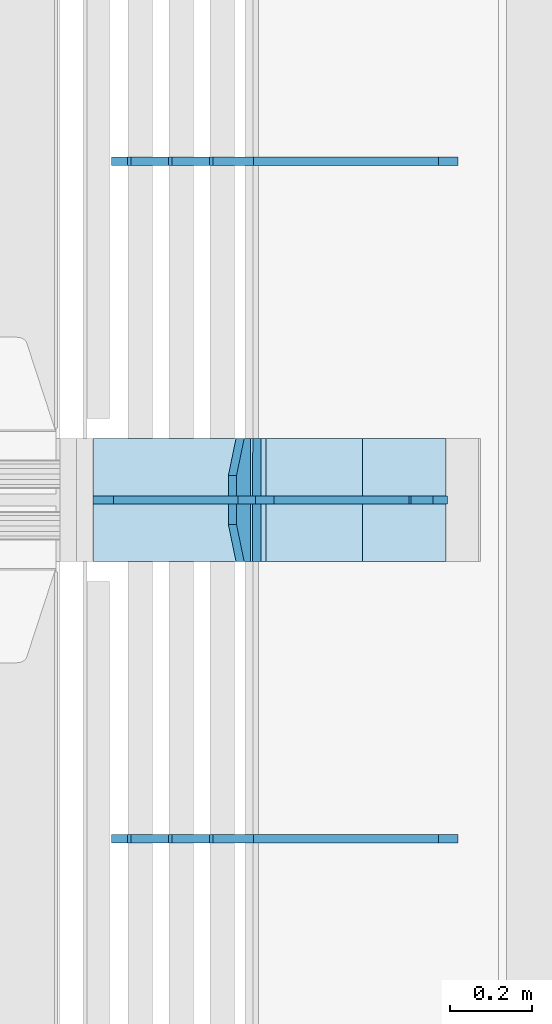
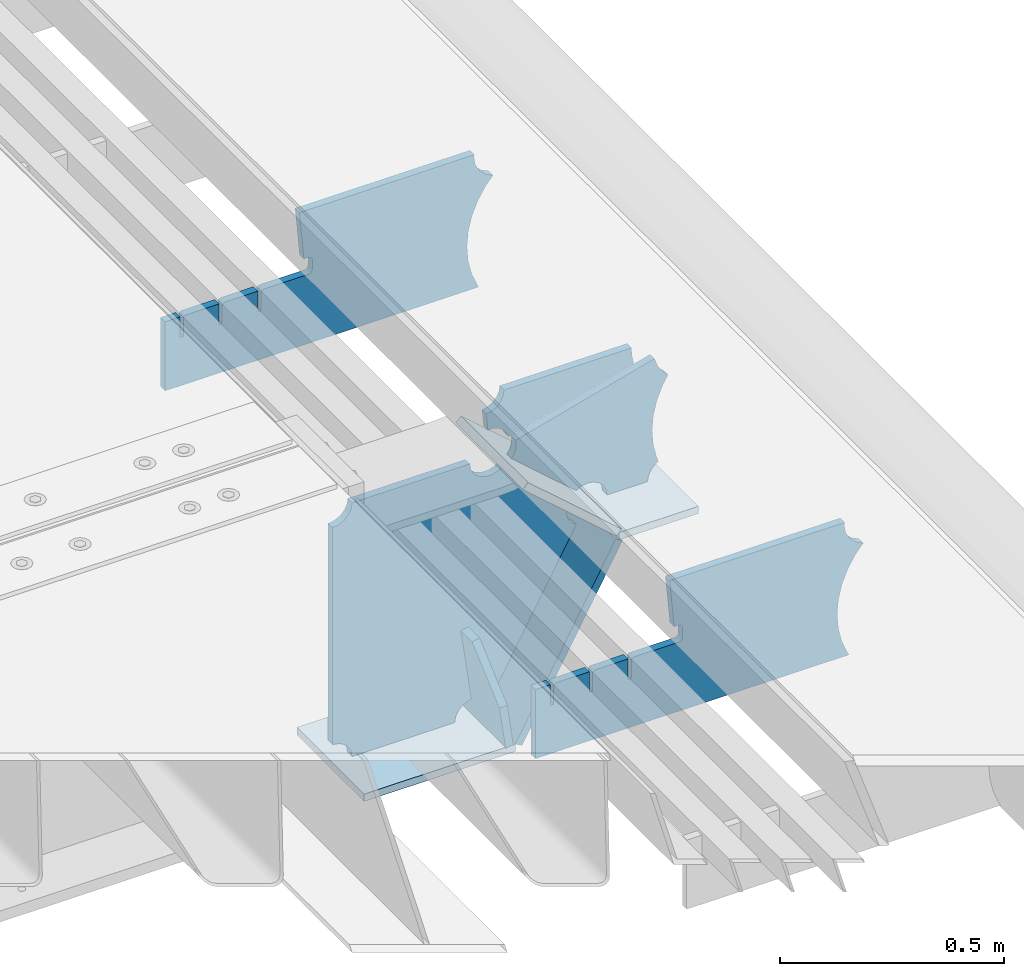
# One storey, part 228 of 247: 10 plates.
"""IFC2X3 building model written with IfcOpenShell, lengths in millimetres."""

from ifc_helpers import new_model, si_unit, frame, origin_with_axes, place, context, subcontext, project, spatial, faceted_brep, material, type_object, element, save


model = new_model("IFC2X3")

# Units and contexts
model_context = context("Model", 3, precision=1e-05, world=origin_with_axes())
body_context = subcontext(model_context, "Body", "Model", "MODEL_VIEW")
ifc_project = project(units=[si_unit("LENGTHUNIT", "METRE", prefix="MILLI"), si_unit("AREAUNIT", "SQUARE_METRE"), si_unit("VOLUMEUNIT", "CUBIC_METRE"), si_unit("MASSUNIT", "GRAM", prefix="KILO"), si_unit("TIMEUNIT", "SECOND"), si_unit("PLANEANGLEUNIT", "RADIAN"), si_unit("SOLIDANGLEUNIT", "STERADIAN"), si_unit("THERMODYNAMICTEMPERATUREUNIT", "DEGREE_CELSIUS"), si_unit("LUMINOUSINTENSITYUNIT", "LUMEN")], contexts=[model_context])

# Site, building, storey
site_placement = place(None, origin_with_axes())
site = spatial("IfcSite", under=ifc_project, at=site_placement, CompositionType="ELEMENT")
building_placement = place(site_placement, origin_with_axes())
building = spatial("IfcBuilding", under=site, at=building_placement, Name="Standard", CompositionType="ELEMENT")
storey_placement = place(building_placement, origin_with_axes())
storey = spatial("IfcBuildingStorey", under=building, at=storey_placement, Name="Undefined", CompositionType="ELEMENT", Elevation=0.0)

# Plates
ifc_material = material(Name="STEEL/S355N")
plate_type_1 = type_object("IfcPlateType", PredefinedType="NOTDEFINED")
plate_1_placement = place(storey_placement, frame((17271.0775331946, 6150.00000000169, -871.412303810021), z_axis=(0.0, -0.999999999999548, -9.5100000000016e-07), x_axis=(-0.137902988002446, 0.0, 0.990445741017648)))
element("IfcPlate", 1, at=plate_1_placement, inside=storey, type_object=plate_type_1, material=ifc_material, context=body_context, shape_type="Brep", body=[
    faceted_brep([(-5.6843418860808e-14, -9.99999999999989, 3.5527136788005e-15), (-1.98724592337385e-10, -10.0000000000036, 300.0), (-1.98724592337385e-10, 10.0, 300.0), (-5.6843418860808e-14, 10.0000000000001, 3.5527136788005e-15), (115.0, -10.0, 300.0), (115.0, 9.99999999999636, 300.0), (250.0, -10.0, 210.0), (250.0, 9.99999999999636, 210.0), (250.0, -10.0, 90.0), (250.0, 9.99999999999636, 90.0), (115.0, -10.0, -1.10503606265411e-10), (115.0, 9.99999999999636, -1.10503606265411e-10)], [[[0, 1, 2, 3]], [[1, 4, 5, 2]], [[4, 6, 7, 5]], [[6, 8, 9, 7]], [[8, 10, 11, 9]], [[10, 0, 3, 11]], [[5, 7, 9, 11, 3, 2]], [[10, 8, 6, 4, 1, 0]]]),
])
plate_type_2 = type_object("IfcPlateType", PredefinedType="NOTDEFINED")
plate_2_placement = place(storey_placement, frame((17299.9988298913, 6000.00000000007, -179.999999999866), z_axis=(0.0, 0.0, -1.0), x_axis=(-1.0, 0.0, 0.0)))
element("IfcPlate", 2, at=plate_2_placement, inside=storey, type_object=plate_type_2, material=ifc_material, context=body_context, shape_type="Brep", body=[
    faceted_brep([(46.0258547361445, 10.0, 641.078828352486), (73.3015011074785, 10.0, 445.179898435767), (73.3015011074785, -10.0, 445.179898435767), (46.0258547361445, -10.0, 641.078828352486), (53.4925862871278, 10.0, 442.421838675718), (53.4925862871278, -10.0, 442.421838675718), (25.7820501123933, 10.0, 641.444230671287), (25.7820501123933, -10.0, 641.444230671287), (54.6652503111618, 10.0, 642.447174185377), (54.6652503111618, -10.0, 642.447174185377), (68.6036632070354, -10.0, 649.549150281387), (68.6036632070354, 10.0, 649.549150281387), (79.6652503111618, -10.0, 660.610737385511), (79.6652503111618, 10.0, 660.610737385511), (86.7672264071698, -10.0, 674.549150281387), (86.7672264071698, 10.0, 674.549150281387), (89.2144005924129, -10.0, 690.0), (89.2144005924129, 10.0, 690.0), (353.0, -10.0, 690.0), (353.0, 10.0, 690.0), (355.447174185243, -10.0, 674.549150281253), (355.447174185243, 10.0, 674.549150281253), (362.549150281251, -10.0, 660.610737385376), (362.549150281251, 10.0, 660.610737385376), (373.610737385377, -10.0, 649.549150281253), (373.610737385377, 10.0, 649.549150281253), (387.549150281251, -10.0, 642.447174185242), (387.549150281251, 10.0, 642.447174185242), (403.0, -10.0, 640.0), (403.0, 10.0, 640.0), (403.0, -10.0, 50.0), (403.0, 10.0, 50.0), (387.549150281251, -10.0, 47.5528258147577), (387.549150281251, 10.0, 47.5528258147577), (373.610737385377, -10.0, 40.4508497187474), (373.610737385377, 10.0, 40.4508497187474), (362.549150281251, -10.0, 29.3892626146236), (362.549150281251, 10.0, 29.3892626146236), (355.447174185243, -10.0, 15.4508497187474), (355.447174185243, 10.0, 15.4508497187474), (353.0, -10.0, 0.0), (353.0, 10.0, 0.0), (50.0, -10.0, 0.0), (50.0, 10.0, 0.0), (47.0349915316328, -10.0, 16.9620037619133), (47.0349915316328, 10.0, 16.9620037619133), (38.4916171352343, -10.0, 31.9123081320451), (38.4916171352343, 10.0, 31.9123081320451), (25.3831239081519, -10.0, 43.0778019479116), (25.3831239081519, 10.0, 43.0778019479116), (9.26418358741648, -10.0, 49.1342538608113), (9.26418358741648, 10.0, 49.1342538608113), (-7.95349204488593, -10.0, 49.363366622344), (-7.95349204488593, 10.0, 49.363366622344), (-24.2278808265401, -10.0, 43.7379673813837), (-24.2278808265401, 10.0, 43.7379673813837), (-37.6288347353438, -10.0, 32.9252303934259), (-37.6288347353438, 10.0, 32.9252303934259), (-210.371165264656, -10.0, 184.074769606574), (-210.371165264656, 10.0, 184.074769606574), (-202.382363280569, -10.0, 196.529747922069), (-202.382363280569, 10.0, 196.529747922069), (-198.388707244045, -10.0, 210.777489969227), (-198.388707244045, 10.0, 210.777489969227), (-198.739957464426, -10.0, 225.570193077959), (-198.739957464426, 10.0, 225.570193077959), (-203.40535180681, -10.0, 239.612327446012), (-203.40535180681, 10.0, 239.612327446012), (-211.976299808361, -10.0, 251.674097313455), (-211.976299808361, 10.0, 251.674097313455), (-223.702166612962, -10.0, 260.699145216992), (-223.702166612962, 10.0, 260.699145216992), (-9.29783338703783, -10.0, 646.300854783008), (-9.29783338703783, 10.0, 646.300854783008), (6.98069453597782, -10.0, 640.647282345602), (6.98069453597782, 10.0, 640.647282345602), (24.2117663163663, -10.0, 640.855891896051), (24.2117663163663, 10.0, 640.855891896051)], [[[0, 1, 2, 3]], [[4, 5, 2, 1]], [[6, 7, 5, 4]], [[8, 9, 10, 11]], [[11, 10, 12, 13]], [[13, 12, 14, 15]], [[15, 14, 16, 17]], [[18, 19, 17, 16]], [[18, 20, 21, 19]], [[20, 22, 23, 21]], [[22, 24, 25, 23]], [[24, 26, 27, 25]], [[26, 28, 29, 27]], [[28, 30, 31, 29]], [[30, 32, 33, 31]], [[32, 34, 35, 33]], [[34, 36, 37, 35]], [[36, 38, 39, 37]], [[38, 40, 41, 39]], [[40, 42, 43, 41]], [[42, 44, 45, 43]], [[44, 46, 47, 45]], [[46, 48, 49, 47]], [[48, 50, 51, 49]], [[50, 52, 53, 51]], [[52, 54, 55, 53]], [[54, 56, 57, 55]], [[56, 58, 59, 57]], [[58, 60, 61, 59]], [[60, 62, 63, 61]], [[62, 64, 65, 63]], [[64, 66, 67, 65]], [[66, 68, 69, 67]], [[68, 70, 71, 69]], [[70, 72, 73, 71]], [[72, 74, 75, 73]], [[74, 76, 77, 75]], [[1, 0, 8, 11, 13, 15, 17, 19, 21, 23, 25, 27, 29, 31, 33, 35, 37, 39, 41, 43, 45, 47, 49, 51, 53, 55, 57, 59, 61, 63, 65, 67, 69, 71, 73, 75, 77, 6, 4]], [[9, 8, 0, 3]], [[76, 74, 72, 70, 68, 66, 64, 62, 60, 58, 56, 54, 52, 50, 48, 46, 44, 42, 40, 38, 36, 34, 32, 30, 28, 26, 24, 22, 20, 18, 16, 14, 12, 10, 9, 3, 2, 5, 7]], [[77, 76, 7, 6]]]),
])
plate_type_3 = type_object("IfcPlateType", PredefinedType="NOTDEFINED")
plate_3_placement = place(storey_placement, frame((17835.9988298906, 6000.0, -9.99999999999716), z_axis=(0.0, 0.0, -1.0), x_axis=(-1.0, 0.0, 0.0)))
element("IfcPlate", 3, at=plate_3_placement, inside=storey, type_object=plate_type_3, material=ifc_material, context=body_context, shape_type="Brep", body=[
    faceted_brep([(164.157641141064, -10.0, 44.1844865875018), (486.718340840864, -10.0, 131.004562768382), (486.718340840864, 10.0, 131.004562768382), (164.157641141064, 10.0, 44.1844865875018), (492.179177700767, -10.0, 118.185717565315), (492.179177700767, 10.0, 118.185717565315), (500.965368826703, -10.0, 107.371542744776), (500.965368826703, 10.0, 107.371542744776), (512.394601349042, -10.0, 99.4018391429503), (512.394601349042, 10.0, 99.4018391429503), (525.579310641864, -10.0, 94.8955133209048), (525.579310641864, 10.0, 94.8955133209048), (539.495606295339, -10.0, 94.2025148824028), (539.495606295339, 10.0, 94.2025148824028), (543.504393704661, -10.0, 49.7974851175972), (543.504393704661, 10.0, 49.7974851175972), (529.167086307516, -10.0, 46.3176139481669), (529.167086307516, 10.0, 46.3176139481669), (516.469507120331, -10.0, 38.8049999196639), (516.469507120331, 10.0, 38.8049999196639), (506.517198234546, -10.0, 27.9137449599276), (506.517198234546, 10.0, 27.9137449599276), (500.17667886756, -10.0, 14.592119649441), (500.17667886756, 10.0, 14.592119649441), (498.0, -10.0, 0.0), (498.0, 10.0, 0.0), (170.0, -10.0, 0.0), (170.0, 10.0, 0.0), (169.632873911985, -10.0, 11.1663820622718), (169.632873911985, 10.0, 11.1663820622718), (168.533081313406, -10.0, 22.2845350637931), (168.533081313406, 10.0, 22.2845350637931), (166.705372351957, -10.0, 33.3064382514178), (166.705372351957, 10.0, 33.3064382514178)], [[[0, 1, 2, 3]], [[1, 4, 5, 2]], [[4, 6, 7, 5]], [[6, 8, 9, 7]], [[8, 10, 11, 9]], [[10, 12, 13, 11]], [[12, 14, 15, 13]], [[14, 16, 17, 15]], [[16, 18, 19, 17]], [[18, 20, 21, 19]], [[20, 22, 23, 21]], [[22, 24, 25, 23]], [[24, 26, 27, 25]], [[26, 28, 29, 27]], [[28, 30, 31, 29]], [[30, 32, 33, 31]], [[32, 0, 3, 33]], [[5, 7, 9, 11, 13, 15, 17, 19, 21, 23, 25, 27, 29, 31, 33, 3, 2]], [[32, 30, 28, 26, 24, 22, 20, 18, 16, 14, 12, 10, 8, 6, 4, 1, 0]]]),
])
plate_type_4 = type_object("IfcPlateType", PredefinedType="NOTDEFINED")
plate_4_placement = place(storey_placement, frame((17840.9988502512, 5999.99999999933, -28.9999913318487), z_axis=(0.260769276985653, 0.0, -0.965401151946889), x_axis=(-0.965401151946889, 0.0, -0.260769276985654)))
element("IfcPlate", 4, at=plate_4_placement, inside=storey, type_object=plate_type_4, material=ifc_material, context=body_context, shape_type="Brep", body=[
    faceted_brep([(183.436474692331, 10.0, 275.852500330424), (184.918388609061, 10.0, 264.417843531322), (184.918388609061, -10.0, 264.417843531322), (183.436474692331, -10.0, 275.852500330424), (183.794583267612, 10.0, 224.576469334607), (183.794583267612, -10.0, 224.576469334607), (176.452049775839, 10.0, 185.401410454621), (176.452049775839, -10.0, 185.401410454621), (163.071585676767, 10.0, 147.857286855558), (163.071585676767, -10.0, 147.857286855558), (143.982662403749, 10.0, 112.868559462227), (143.982662403749, -10.0, 112.868559462227), (119.655312600251, 10.0, 81.2967668639831), (119.655312600251, -10.0, 81.2967668639831), (100.960891712752, 10.0, 63.6280409830933), (100.960891712752, -10.0, 63.6280409830933), (194.486836975902, -10.0, 278.751956446687), (207.178624553377, -10.0, 286.650994937514), (207.178624553377, 10.0, 286.650994937514), (194.486836975902, 10.0, 278.751956446687), (216.968013469446, -10.0, 297.948965801394), (216.968013469446, 10.0, 297.948965801394), (222.979925232863, -10.0, 311.635937633766), (222.979925232863, 10.0, 311.635937633766), (323.381647032762, -10.0, 284.515917834983), (323.381647032762, 10.0, 284.515917834983), (321.720617177336, -10.0, 268.853198956859), (321.720617177336, 10.0, 268.853198956859), (325.01434448114, -10.0, 253.450889283181), (325.01434448114, 10.0, 253.450889283181), (332.935986082481, -10.0, 239.837389469553), (332.935986082481, 10.0, 239.837389469553), (344.699462330093, -10.0, 229.363593146935), (344.699462330093, 10.0, 229.363593146935), (359.137460970807, -10.0, 223.0688351622), (359.137460970807, 10.0, 223.0688351622), (374.817271777687, -10.0, 221.57775639289), (374.817271777687, 10.0, 221.57775639289), (390.182952880859, -10.0, 225.038330078124), (390.182952880859, 10.0, 225.038330078124), (512.90906051303, -10.0, 41.5599003357011), (512.90906051303, 10.0, 41.5599003357011), (503.648024844581, -10.0, 33.5643666747665), (503.648024844581, 10.0, 33.5643666747665), (496.606064569703, -10.0, 23.5590612989981), (496.606064569703, 10.0, 23.5590612989981), (492.204839143935, -10.0, 12.1430832451069), (492.204839143935, 10.0, 12.1430832451069), (490.707885742188, -10.0, 3.79259290639311e-10), (490.707885742188, 10.0, 3.79259290639311e-10), (120.0, -10.0, 9.18589648790658e-11), (120.0, 10.0, 9.18589648790658e-11), (117.226254779114, -10.0, 25.6516118492136), (117.226254779114, 10.0, 25.6516118492136), (109.03324682566, -10.0, 50.1173731020972), (109.03324682566, 10.0, 50.1173731020972)], [[[0, 1, 2, 3]], [[4, 5, 2, 1]], [[6, 7, 5, 4]], [[8, 9, 7, 6]], [[10, 11, 9, 8]], [[12, 13, 11, 10]], [[14, 15, 13, 12]], [[16, 17, 18, 19]], [[17, 20, 21, 18]], [[20, 22, 23, 21]], [[22, 24, 25, 23]], [[24, 26, 27, 25]], [[26, 28, 29, 27]], [[28, 30, 31, 29]], [[30, 32, 33, 31]], [[32, 34, 35, 33]], [[34, 36, 37, 35]], [[36, 38, 39, 37]], [[38, 40, 41, 39]], [[40, 42, 43, 41]], [[42, 44, 45, 43]], [[44, 46, 47, 45]], [[46, 48, 49, 47]], [[48, 50, 51, 49]], [[50, 52, 53, 51]], [[52, 54, 55, 53]], [[10, 8, 6, 4, 1, 0, 19, 18, 21, 23, 25, 27, 29, 31, 33, 35, 37, 39, 41, 43, 45, 47, 49, 51, 53, 55, 14, 12]], [[16, 19, 0, 3]], [[54, 52, 50, 48, 46, 44, 42, 40, 38, 36, 34, 32, 30, 28, 26, 24, 22, 20, 17, 16, 3, 2, 5, 7, 9, 11, 13, 15]], [[55, 54, 15, 14]]]),
])
plate_type_5 = type_object("IfcPlateType", PredefinedType="NOTDEFINED")
plate_5_placement = place(storey_placement, frame((17312.2260590443, 6149.99999999933, -177.219372761326), z_axis=(0.752414935148685, 0.0, -0.658689430130164), x_axis=(0.0, -0.999999999999548, -9.5100000000016e-07)))
element("IfcPlate", 5, at=plate_5_placement, inside=storey, type_object=plate_type_5, material=ifc_material, context=body_context, shape_type="Brep", body=[
    faceted_brep([(-5.6843418860808e-14, -9.99999999999989, 3.5527136788005e-15), (1.09139364212751e-10, -10.0000000000018, 320.0), (1.09139364212751e-10, 9.99999999999818, 319.999999999998), (-5.6843418860808e-14, 10.0000000000001, 3.5527136788005e-15), (300.0, -10.0000000000018, 320.0), (300.0, 9.99999999999818, 319.999999999998), (300.0, -10.0, 6.54836185276508e-11), (300.0, 9.99999999999818, 6.54836185276508e-11)], [[[0, 1, 2, 3]], [[1, 4, 5, 2]], [[4, 6, 7, 5]], [[6, 0, 3, 7]], [[5, 7, 3, 2]], [[6, 4, 1, 0]]]),
])
plate_6_placement = place(storey_placement, frame((17553.0007288108, 6150.00000000007, -408.004820491625), z_axis=(-0.484064236150485, 0.0, -0.875032465272031), x_axis=(0.0, -0.999999999999548, -9.5100000000016e-07)))
element("IfcPlate", 6, at=plate_6_placement, inside=storey, type_object=plate_type_5, material=ifc_material, context=body_context, shape_type="Brep", body=[
    faceted_brep([(-5.6843418860808e-14, -9.99999999999989, 3.5527136788005e-15), (3.86515239370056e-07, -10.0, 533.528442382813), (3.86515239370056e-07, 9.99999999999818, 533.528442382813), (-5.6843418860808e-14, 10.0000000000001, 3.5527136788005e-15), (300.003295898438, -10.0, 533.549133300782), (300.003295898438, 9.99999999999818, 533.549133300781), (300.0, -10.0, 6.54836185276508e-11), (300.0, 9.99999999999818, 6.54836185276508e-11)], [[[0, 1, 2, 3]], [[1, 4, 5, 2]], [[4, 6, 7, 5]], [[6, 0, 3, 7]], [[5, 7, 3, 2]], [[6, 4, 1, 0]]]),
])
plate_7_placement = place(storey_placement, frame((16896.9988298913, 6150.00000000007, -879.999999999866), z_axis=(0.0, -0.999999999999548, -9.5100000000016e-07), x_axis=(1.0, 0.0, 0.0)))
element("IfcPlate", 7, at=plate_7_placement, inside=storey, type_object=plate_type_5, material=ifc_material, context=body_context, shape_type="Brep", body=[
    faceted_brep([(-5.6843418860808e-14, -9.99999999999989, 3.5527136788005e-15), (-1.98724592337385e-10, -10.0000000000036, 300.0), (-1.98724592337385e-10, 10.0, 300.0), (-5.6843418860808e-14, 10.0000000000001, 3.5527136788005e-15), (389.0, -10.0, 300.0), (389.0, 10.0, 300.0), (389.0, -10.0, 0.0), (389.0, 10.0, 0.0)], [[[0, 1, 2, 3]], [[1, 4, 5, 2]], [[4, 6, 7, 5]], [[6, 0, 3, 7]], [[5, 7, 3, 2]], [[6, 4, 1, 0]]]),
])
plate_type_6 = type_object("IfcPlateType", PredefinedType="NOTDEFINED")
plate_8_placement = place(storey_placement, frame((17756.9988298913, 6149.99999999933, -397.999999999763), z_axis=(-1.0, 0.0, 0.0), x_axis=(0.0, -0.999999999999548, -9.5100000000016e-07)))
element("IfcPlate", 8, at=plate_8_placement, inside=storey, type_object=plate_type_6, material=ifc_material, context=body_context, shape_type="Brep", body=[
    faceted_brep([(-5.6843418860808e-14, -9.99999999999989, 3.5527136788005e-15), (4.63842297904193e-10, -10.0, 204.0), (4.63842297904193e-10, 10.0, 204.0), (-5.6843418860808e-14, 10.0000000000001, 3.5527136788005e-15), (300.0, -10.0, 204.0), (300.0, 10.0, 204.0), (300.0, -10.0, 6.54836185276508e-11), (300.0, 9.99999999999818, 6.54836185276508e-11)], [[[0, 1, 2, 3]], [[1, 4, 5, 2]], [[4, 6, 7, 5]], [[6, 0, 3, 7]], [[5, 7, 3, 2]], [[6, 4, 1, 0]]]),
])
plate_type_7 = type_object("IfcPlateType", PredefinedType="NOTDEFINED")
plate_9_placement = place(storey_placement, frame((17782.9182339676, 5174.99928283691, -374.002067436516), z_axis=(0.0, 0.0, 1.0), x_axis=(-1.0, 0.0, 0.0)))
element("IfcPlate", 9, at=plate_9_placement, inside=storey, type_object=plate_type_7, material=ifc_material, context=body_context, shape_type="Brep", body=[
    faceted_brep([(801.919404066546, -10.0, 188.0), (801.919404066546, 10.0, 188.0), (801.919404066546, 10.0, 132.002067436952), (801.919404066546, -10.0, 132.002067436952), (793.919404066546, 10.0, 132.002067436952), (793.919404066546, -10.0, 132.002067436952), (793.919404066546, 10.0, 180.002067436952), (793.919404066546, -10.0, 180.002067436952), (793.527856196906, 10.0, 182.474203391951), (793.527856196906, -10.0, 182.474203391951), (792.391540021545, 10.0, 184.704349455291), (792.391540021545, -10.0, 184.704349455291), (790.621686084887, 10.0, 186.474203391951), (790.621686084887, -10.0, 186.474203391951), (788.391540021545, 10.0, 187.610519567313), (788.391540021545, -10.0, 187.610519567313), (785.919404066546, -10.0, 188.002067436952), (785.919404066546, 10.0, 188.0), (841.0, -10.0, 188.0), (841.0, -10.0, 0.0), (841.0, 10.0, 0.0), (841.0, 10.0, 188.0), (33.3619566736015, -10.0, 0.0), (33.3619566736015, 10.0, 0.0), (36.2350612208174, -10.0, 4.68848050267013), (36.2350612208174, 10.0, 4.68848050267013), (51.4877592159428, -10.0, 41.5117508652784), (51.4877592159428, 10.0, 41.5117508652784), (60.792242588137, -10.0, 80.2677133162964), (60.792242588137, 10.0, 80.2677133162964), (63.9194040769726, -10.0, 120.002067436515), (63.9194040769726, 10.0, 120.002067436515), (60.792242588137, -10.0, 159.736421556734), (60.792242588137, 10.0, 159.736421556734), (51.4877592159428, -10.0, 198.492384007752), (51.4877592159428, 10.0, 198.492384007752), (36.2350612208174, -10.0, 235.31565437036), (36.2350612208174, 10.0, 235.31565437036), (15.4097206482074, -10.0, 269.299521518803), (15.4097206482074, 10.0, 269.299521518803), (-3.35474438098754, -10.0, 291.269887256574), (-3.35474438098754, 10.0, 291.269887256574), (-2.36881039375294, -10.0, 291.426043859339), (-2.36881039375294, 10.0, 291.426043859339), (17.1449676604716, -10.0, 301.368810393754), (17.1449676604716, 10.0, 301.368810393754), (32.6311896062471, -10.0, 316.855032339527), (32.6311896062471, 10.0, 316.855032339527), (42.573956140659, -10.0, 336.368810393754), (42.573956140659, 10.0, 336.368810393754), (46.0, -10.0, 358.0), (46.0, 10.0, 358.0), (45.0495205499137, -10.0, 364.001091067617), (45.0495205499137, 10.0, 364.001091067617), (495.040008544922, -10.0, 364.010009765625), (495.040008544922, 10.0, 364.010009765625), (483.600036621094, -10.0, 233.759994506836), (483.600036621094, 10.0, 233.759994506836), (472.0, -10.0, 233.759994506836), (472.0, 10.0, 233.759994506836), (468.909830056251, -10.0, 233.270559669787), (468.909830056251, 10.0, 233.270559669787), (466.122147477075, -10.0, 231.850164450585), (466.122147477075, 10.0, 231.850164450585), (463.909830056251, -10.0, 229.637847029761), (463.909830056251, 10.0, 229.637847029761), (462.489434837047, -10.0, 226.850164450585), (462.489434837047, 10.0, 226.850164450585), (462.0, -10.0, 223.759994506836), (462.0, 10.0, 223.759994506836), (462.0, -10.0, 198.0), (462.0, 10.0, 198.0), (462.489434837047, -10.0, 194.909830056251), (462.489434837047, 10.0, 194.909830056251), (463.909830056251, -10.0, 192.122147477075), (463.909830056251, 10.0, 192.122147477075), (466.122147477075, -10.0, 189.909830056251), (466.122147477075, 10.0, 189.909830056251), (468.909830056251, -10.0, 188.489434837048), (468.909830056251, 10.0, 188.489434837048), (472.0, -10.0, 188.0), (472.0, 10.0, 188.0), (585.919404066546, -10.0, 188.002067436952), (585.919404066546, 10.0, 188.0), (588.391540021545, -10.0, 187.610519567313), (588.391540021545, 10.0, 187.610519567313), (590.621686084887, -10.0, 186.474203391951), (590.621686084887, 10.0, 186.474203391951), (592.391540021545, -10.0, 184.704349455291), (592.391540021545, 10.0, 184.704349455291), (593.527856196906, -10.0, 182.474203391951), (593.527856196906, 10.0, 182.474203391951), (593.919404066546, -10.0, 180.002067436952), (593.919404066546, 10.0, 180.002067436952), (593.919404066546, -10.0, 132.002067436952), (593.919404066546, 10.0, 132.002067436952), (601.919404066546, -10.0, 132.002067436952), (601.919404066546, 10.0, 132.002067436952), (601.919404066546, -10.0, 188.0), (601.919404066546, 10.0, 188.0), (685.919404066546, -10.0, 188.002067436952), (685.919404066546, 10.0, 188.0), (688.391540021545, -10.0, 187.610519567313), (688.391540021545, 10.0, 187.610519567313), (690.621686084887, -10.0, 186.474203391951), (690.621686084887, 10.0, 186.474203391951), (692.391540021545, -10.0, 184.704349455291), (692.391540021545, 10.0, 184.704349455291), (693.527856196906, -10.0, 182.474203391951), (693.527856196906, 10.0, 182.474203391951), (693.919404066546, -10.0, 180.002067436952), (693.919404066546, 10.0, 180.002067436952), (693.919404066546, -10.0, 132.002067436952), (693.919404066546, 10.0, 132.002067436952), (701.919404066546, -10.0, 132.002067436952), (701.919404066546, 10.0, 132.002067436952), (701.919404066546, -10.0, 188.0), (701.919404066546, 10.0, 188.0)], [[[0, 1, 2, 3]], [[3, 2, 4, 5]], [[5, 4, 6, 7]], [[7, 6, 8, 9]], [[9, 8, 10, 11]], [[11, 10, 12, 13]], [[13, 12, 14, 15]], [[16, 15, 14, 17]], [[18, 19, 20, 21]], [[20, 19, 22, 23]], [[22, 24, 25, 23]], [[26, 27, 25, 24]], [[28, 29, 27, 26]], [[30, 31, 29, 28]], [[32, 33, 31, 30]], [[34, 35, 33, 32]], [[36, 37, 35, 34]], [[38, 39, 37, 36]], [[39, 38, 40, 41]], [[40, 42, 43, 41]], [[44, 45, 43, 42]], [[46, 47, 45, 44]], [[48, 49, 47, 46]], [[50, 51, 49, 48]], [[52, 53, 51, 50]], [[54, 55, 53, 52]], [[54, 56, 57, 55]], [[56, 58, 59, 57]], [[58, 60, 61, 59]], [[60, 62, 63, 61]], [[62, 64, 65, 63]], [[64, 66, 67, 65]], [[66, 68, 69, 67]], [[68, 70, 71, 69]], [[70, 72, 73, 71]], [[72, 74, 75, 73]], [[74, 76, 77, 75]], [[76, 78, 79, 77]], [[78, 80, 81, 79]], [[81, 80, 82, 83]], [[82, 84, 85, 83]], [[86, 87, 85, 84]], [[88, 89, 87, 86]], [[90, 91, 89, 88]], [[92, 93, 91, 90]], [[94, 95, 93, 92]], [[96, 97, 95, 94]], [[98, 99, 97, 96]], [[99, 98, 100, 101]], [[100, 102, 103, 101]], [[104, 105, 103, 102]], [[106, 107, 105, 104]], [[108, 109, 107, 106]], [[110, 111, 109, 108]], [[112, 113, 111, 110]], [[114, 115, 113, 112]], [[116, 117, 115, 114]], [[117, 116, 16, 17]], [[12, 10, 8, 6, 4, 2, 1, 21, 20, 23, 25, 27, 29, 31, 33, 35, 37, 39, 41, 43, 45, 47, 49, 51, 53, 55, 57, 59, 61, 63, 65, 67, 69, 71, 73, 75, 77, 79, 81, 83, 85, 87, 89, 91, 93, 95, 97, 99, 101, 103, 105, 107, 109, 111, 113, 115, 117, 17, 14]], [[18, 21, 1, 0]], [[116, 114, 112, 110, 108, 106, 104, 102, 100, 98, 96, 94, 92, 90, 88, 86, 84, 82, 80, 78, 76, 74, 72, 70, 68, 66, 64, 62, 60, 58, 56, 54, 52, 50, 48, 46, 44, 42, 40, 38, 36, 34, 32, 30, 28, 26, 24, 22, 19, 18, 0, 3, 5, 7, 9, 11, 13, 15, 16]]]),
])
plate_10_placement = place(storey_placement, frame((17782.9182339676, 6824.99928283691, -374.002067436516), z_axis=(0.0, 0.0, 1.0), x_axis=(-1.0, 0.0, 0.0)))
element("IfcPlate", 10, at=plate_10_placement, inside=storey, type_object=plate_type_7, material=ifc_material, context=body_context, shape_type="Brep", body=[
    faceted_brep([(801.919404066546, -10.0, 188.0), (801.919404066546, 10.0, 188.0), (801.919404066546, 10.0, 132.002067436952), (801.919404066546, -10.0, 132.002067436952), (793.919404066546, 10.0, 132.002067436952), (793.919404066546, -10.0, 132.002067436952), (793.919404066546, 10.0, 180.002067436952), (793.919404066546, -10.0, 180.002067436952), (793.527856196906, 10.0, 182.474203391951), (793.527856196906, -10.0, 182.474203391951), (792.391540021545, 10.0, 184.704349455291), (792.391540021545, -10.0, 184.704349455291), (790.621686084887, 10.0, 186.474203391951), (790.621686084887, -10.0, 186.474203391951), (788.391540021545, 10.0, 187.610519567313), (788.391540021545, -10.0, 187.610519567313), (785.919404066546, -10.0, 188.002067436952), (785.919404066546, 10.0, 188.0), (841.0, -10.0, 188.0), (841.0, -10.0, 0.0), (841.0, 10.0, 0.0), (841.0, 10.0, 188.0), (33.3619566736015, -10.0, 0.0), (33.3619566736015, 10.0, 0.0), (36.2350612208174, -10.0, 4.68848050267013), (36.2350612208174, 10.0, 4.68848050267013), (51.4877592159428, -10.0, 41.5117508652784), (51.4877592159428, 10.0, 41.5117508652784), (60.792242588137, -10.0, 80.2677133162964), (60.792242588137, 10.0, 80.2677133162964), (63.9194040769726, -10.0, 120.002067436515), (63.9194040769726, 10.0, 120.002067436515), (60.792242588137, -10.0, 159.736421556734), (60.792242588137, 10.0, 159.736421556734), (51.4877592159428, -10.0, 198.492384007752), (51.4877592159428, 10.0, 198.492384007752), (36.2350612208174, -10.0, 235.31565437036), (36.2350612208174, 10.0, 235.31565437036), (15.4097206482074, -10.0, 269.299521518803), (15.4097206482074, 10.0, 269.299521518803), (-3.35474438098754, -10.0, 291.269887256574), (-3.35474438098754, 10.0, 291.269887256574), (-2.36881039375294, -10.0, 291.426043859339), (-2.36881039375294, 10.0, 291.426043859339), (17.1449676604716, -10.0, 301.368810393754), (17.1449676604716, 10.0, 301.368810393754), (32.6311896062471, -10.0, 316.855032339527), (32.6311896062471, 10.0, 316.855032339527), (42.573956140659, -10.0, 336.368810393754), (42.573956140659, 10.0, 336.368810393754), (46.0, -10.0, 358.0), (46.0, 10.0, 358.0), (45.0495205499137, -10.0, 364.001091067617), (45.0495205499137, 10.0, 364.001091067617), (495.040008544922, -10.0, 364.010009765625), (495.040008544922, 10.0, 364.010009765625), (483.600036621094, -10.0, 233.759994506836), (483.600036621094, 10.0, 233.759994506836), (472.0, -10.0, 233.759994506836), (472.0, 10.0, 233.759994506836), (468.909830056251, -10.0, 233.270559669787), (468.909830056251, 10.0, 233.270559669787), (466.122147477075, -10.0, 231.850164450585), (466.122147477075, 10.0, 231.850164450585), (463.909830056251, -10.0, 229.637847029761), (463.909830056251, 10.0, 229.637847029761), (462.489434837047, -10.0, 226.850164450585), (462.489434837047, 10.0, 226.850164450585), (462.0, -10.0, 223.759994506836), (462.0, 10.0, 223.759994506836), (462.0, -10.0, 198.0), (462.0, 10.0, 198.0), (462.489434837047, -10.0, 194.909830056251), (462.489434837047, 10.0, 194.909830056251), (463.909830056251, -10.0, 192.122147477075), (463.909830056251, 10.0, 192.122147477075), (466.122147477075, -10.0, 189.909830056251), (466.122147477075, 10.0, 189.909830056251), (468.909830056251, -10.0, 188.489434837048), (468.909830056251, 10.0, 188.489434837048), (472.0, -10.0, 188.0), (472.0, 10.0, 188.0), (585.919404066546, -10.0, 188.002067436952), (585.919404066546, 10.0, 188.0), (588.391540021545, -10.0, 187.610519567313), (588.391540021545, 10.0, 187.610519567313), (590.621686084887, -10.0, 186.474203391951), (590.621686084887, 10.0, 186.474203391951), (592.391540021545, -10.0, 184.704349455291), (592.391540021545, 10.0, 184.704349455291), (593.527856196906, -10.0, 182.474203391951), (593.527856196906, 10.0, 182.474203391951), (593.919404066546, -10.0, 180.002067436952), (593.919404066546, 10.0, 180.002067436952), (593.919404066546, -10.0, 132.002067436952), (593.919404066546, 10.0, 132.002067436952), (601.919404066546, -10.0, 132.002067436952), (601.919404066546, 10.0, 132.002067436952), (601.919404066546, -10.0, 188.0), (601.919404066546, 10.0, 188.0), (685.919404066546, -10.0, 188.002067436952), (685.919404066546, 10.0, 188.0), (688.391540021545, -10.0, 187.610519567313), (688.391540021545, 10.0, 187.610519567313), (690.621686084887, -10.0, 186.474203391951), (690.621686084887, 10.0, 186.474203391951), (692.391540021545, -10.0, 184.704349455291), (692.391540021545, 10.0, 184.704349455291), (693.527856196906, -10.0, 182.474203391951), (693.527856196906, 10.0, 182.474203391951), (693.919404066546, -10.0, 180.002067436952), (693.919404066546, 10.0, 180.002067436952), (693.919404066546, -10.0, 132.002067436952), (693.919404066546, 10.0, 132.002067436952), (701.919404066546, -10.0, 132.002067436952), (701.919404066546, 10.0, 132.002067436952), (701.919404066546, -10.0, 188.0), (701.919404066546, 10.0, 188.0)], [[[0, 1, 2, 3]], [[3, 2, 4, 5]], [[5, 4, 6, 7]], [[7, 6, 8, 9]], [[9, 8, 10, 11]], [[11, 10, 12, 13]], [[13, 12, 14, 15]], [[16, 15, 14, 17]], [[18, 19, 20, 21]], [[20, 19, 22, 23]], [[22, 24, 25, 23]], [[26, 27, 25, 24]], [[28, 29, 27, 26]], [[30, 31, 29, 28]], [[32, 33, 31, 30]], [[34, 35, 33, 32]], [[36, 37, 35, 34]], [[38, 39, 37, 36]], [[39, 38, 40, 41]], [[40, 42, 43, 41]], [[44, 45, 43, 42]], [[46, 47, 45, 44]], [[48, 49, 47, 46]], [[50, 51, 49, 48]], [[52, 53, 51, 50]], [[54, 55, 53, 52]], [[54, 56, 57, 55]], [[56, 58, 59, 57]], [[58, 60, 61, 59]], [[60, 62, 63, 61]], [[62, 64, 65, 63]], [[64, 66, 67, 65]], [[66, 68, 69, 67]], [[68, 70, 71, 69]], [[70, 72, 73, 71]], [[72, 74, 75, 73]], [[74, 76, 77, 75]], [[76, 78, 79, 77]], [[78, 80, 81, 79]], [[81, 80, 82, 83]], [[82, 84, 85, 83]], [[86, 87, 85, 84]], [[88, 89, 87, 86]], [[90, 91, 89, 88]], [[92, 93, 91, 90]], [[94, 95, 93, 92]], [[96, 97, 95, 94]], [[98, 99, 97, 96]], [[99, 98, 100, 101]], [[100, 102, 103, 101]], [[104, 105, 103, 102]], [[106, 107, 105, 104]], [[108, 109, 107, 106]], [[110, 111, 109, 108]], [[112, 113, 111, 110]], [[114, 115, 113, 112]], [[116, 117, 115, 114]], [[117, 116, 16, 17]], [[12, 10, 8, 6, 4, 2, 1, 21, 20, 23, 25, 27, 29, 31, 33, 35, 37, 39, 41, 43, 45, 47, 49, 51, 53, 55, 57, 59, 61, 63, 65, 67, 69, 71, 73, 75, 77, 79, 81, 83, 85, 87, 89, 91, 93, 95, 97, 99, 101, 103, 105, 107, 109, 111, 113, 115, 117, 17, 14]], [[18, 21, 1, 0]], [[116, 114, 112, 110, 108, 106, 104, 102, 100, 98, 96, 94, 92, 90, 88, 86, 84, 82, 80, 78, 76, 74, 72, 70, 68, 66, 64, 62, 60, 58, 56, 54, 52, 50, 48, 46, 44, 42, 40, 38, 36, 34, 32, 30, 28, 26, 24, 22, 19, 18, 0, 3, 5, 7, 9, 11, 13, 15, 16]]]),
])

save(model, "model.ifc")
